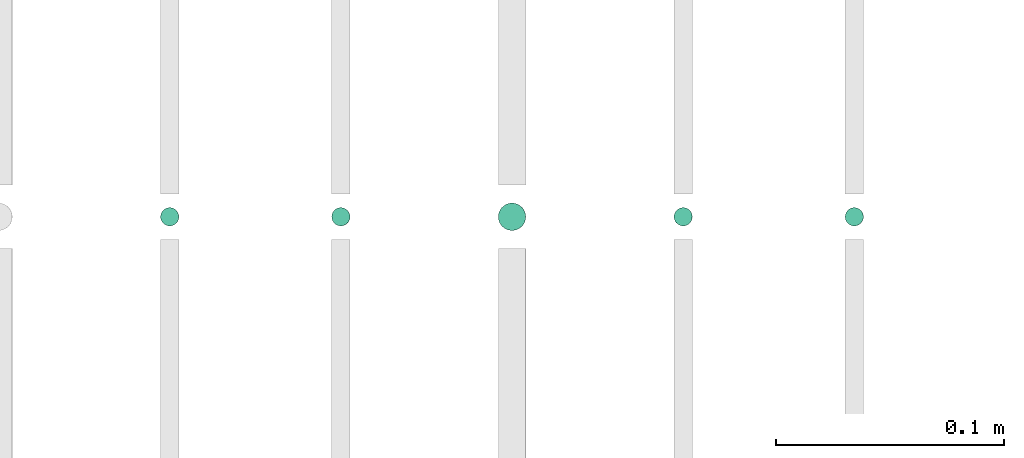
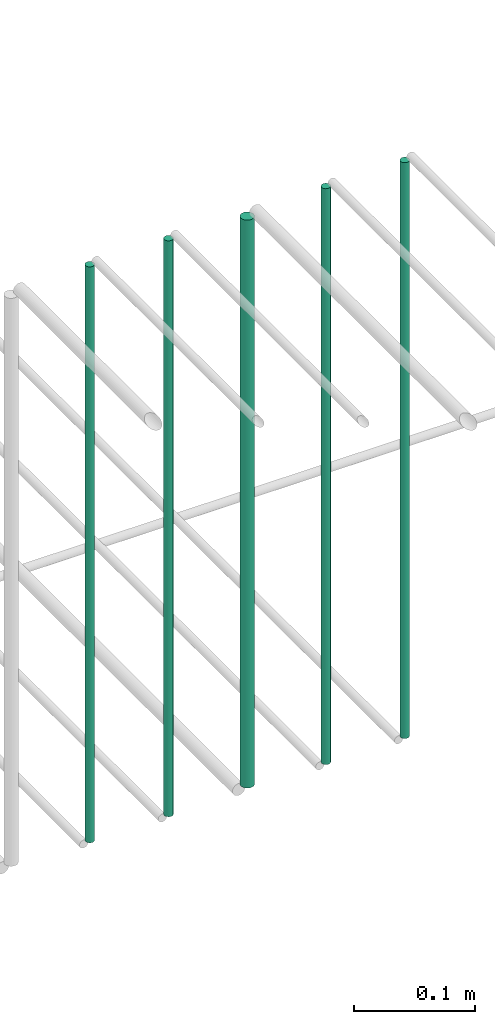
# One storey, part 178 of 331: 5 flow segments.
"""IFC2X3 building model written with IfcOpenShell, lengths in millimetres."""

from ifc_helpers import new_model, entity, si_unit, converted_unit, derived_unit, direction, frame, frame_2d, origin, origin_2d_with_axis, place, context, subcontext, project, spatial, circle, extrude, type_object, element, save


model = new_model("IFC2X3")

# Units and contexts
model_context = context("Model", 3, precision=0.01, world=origin(), true_north=direction((6.12303176911189e-17, 1.0)))
body_context = subcontext(model_context, "Body", "Model", "MODEL_VIEW")
ifc_project = project(units=[si_unit("LENGTHUNIT", "METRE", prefix="MILLI"), si_unit("AREAUNIT", "SQUARE_METRE"), si_unit("VOLUMEUNIT", "CUBIC_METRE"), converted_unit("PLANEANGLEUNIT", "DEGREE", entity("IfcRatioMeasure", 0.0174532925199433), si_unit("PLANEANGLEUNIT", "RADIAN"), dimensions=[0, 0, 0, 0, 0, 0, 0]), si_unit("MASSUNIT", "GRAM", prefix="KILO"), derived_unit("MASSDENSITYUNIT", [(si_unit("MASSUNIT", "GRAM", prefix="KILO"), 1), (si_unit("LENGTHUNIT", "METRE"), -3)]), derived_unit("MOMENTOFINERTIAUNIT", [(si_unit("LENGTHUNIT", "METRE"), 4)]), si_unit("TIMEUNIT", "SECOND"), si_unit("FREQUENCYUNIT", "HERTZ"), si_unit("THERMODYNAMICTEMPERATUREUNIT", "DEGREE_CELSIUS"), derived_unit("THERMALTRANSMITTANCEUNIT", [(si_unit("MASSUNIT", "GRAM", prefix="KILO"), 1), (si_unit("THERMODYNAMICTEMPERATUREUNIT", "KELVIN"), -1), (si_unit("TIMEUNIT", "SECOND"), -3)]), derived_unit("VOLUMETRICFLOWRATEUNIT", [(si_unit("LENGTHUNIT", "METRE"), 3), (si_unit("TIMEUNIT", "SECOND"), -1)]), derived_unit("MASSFLOWRATEUNIT", [(si_unit("MASSUNIT", "GRAM", prefix="KILO"), 1), (si_unit("TIMEUNIT", "SECOND"), -1)]), derived_unit("ROTATIONALFREQUENCYUNIT", [(si_unit("TIMEUNIT", "SECOND"), -1)]), si_unit("ELECTRICCURRENTUNIT", "AMPERE"), si_unit("ELECTRICVOLTAGEUNIT", "VOLT"), si_unit("POWERUNIT", "WATT"), si_unit("FORCEUNIT", "NEWTON", prefix="KILO"), si_unit("ILLUMINANCEUNIT", "LUX"), si_unit("LUMINOUSFLUXUNIT", "LUMEN"), si_unit("LUMINOUSINTENSITYUNIT", "CANDELA"), derived_unit("USERDEFINED", [(si_unit("MASSUNIT", "GRAM", prefix="KILO"), -1), (si_unit("LENGTHUNIT", "METRE"), -2), (si_unit("TIMEUNIT", "SECOND"), 3), (si_unit("LUMINOUSFLUXUNIT", "LUMEN"), 1)]), derived_unit("LINEARVELOCITYUNIT", [(si_unit("LENGTHUNIT", "METRE"), 1), (si_unit("TIMEUNIT", "SECOND"), -1)]), si_unit("PRESSUREUNIT", "PASCAL"), derived_unit("USERDEFINED", [(si_unit("LENGTHUNIT", "METRE"), -2), (si_unit("MASSUNIT", "GRAM", prefix="KILO"), 1), (si_unit("TIMEUNIT", "SECOND"), -2)]), derived_unit("LINEARFORCEUNIT", [(si_unit("MASSUNIT", "GRAM", prefix="KILO"), 1), (si_unit("LENGTHUNIT", "METRE"), 1), (si_unit("TIMEUNIT", "SECOND"), -2), (si_unit("LENGTHUNIT", "METRE"), -1)]), derived_unit("PLANARFORCEUNIT", [(si_unit("MASSUNIT", "GRAM", prefix="KILO"), 1), (si_unit("LENGTHUNIT", "METRE"), 1), (si_unit("TIMEUNIT", "SECOND"), -2), (si_unit("LENGTHUNIT", "METRE"), -2)])], contexts=[model_context])

# Site, building, storey
site_placement = place(None, frame((0.0, -0.00077364408347762, 0.0)))
site = spatial("IfcSite", under=ifc_project, at=site_placement, CompositionType="ELEMENT")
building_placement = place(site_placement, origin())
building = spatial("IfcBuilding", under=site, at=building_placement, CompositionType="ELEMENT")
storey_placement = place(building_placement, origin())
storey = spatial("IfcBuildingStorey", under=building, at=storey_placement, CompositionType="ELEMENT", Elevation=0.0)

# Flow segments
pipe_segment_type = type_object("IfcPipeSegmentType", PredefinedType="NOTDEFINED")
flow_segment_1_placement = place(storey_placement, frame((44864.5706481368, 5638.02529159143, 18460.0)))
element("IfcFlowSegment", 1, at=flow_segment_1_placement, inside=storey, type_object=pipe_segment_type, context=body_context, shape_type="SweptSolid", body=[
    extrude(circle(Radius=4.0, at=origin_2d_with_axis()), frame((5.59527223591499, 5.59527223591607, 0.0), z_axis=(0.0, 0.0, 1.0), x_axis=(-1.0, 0.0, 0.0)), (0.0, 0.0, 1.0), 580.000000000015),
])
flow_segment_2_placement = place(storey_placement, frame((44789.5706481368, 5638.02529159143, 18460.0)))
element("IfcFlowSegment", 2, at=flow_segment_2_placement, inside=storey, type_object=pipe_segment_type, context=body_context, shape_type="SweptSolid", body=[
    extrude(circle(Radius=4.0, at=origin_2d_with_axis()), frame((5.59527223591499, 5.59527223591607, 0.0), z_axis=(0.0, 0.0, 1.0), x_axis=(-1.0, 0.0, 0.0)), (0.0, 0.0, 1.0), 580.000000000007),
])
flow_segment_3_placement = place(storey_placement, frame((44712.5706481368, 5636.02529159143, 18464.0)))
element("IfcFlowSegment", 3, at=flow_segment_3_placement, inside=storey, type_object=pipe_segment_type, context=body_context, shape_type="SweptSolid", body=[
    extrude(circle(Radius=6.0, at=origin_2d_with_axis()), frame((7.59527223591454, 7.59527223591562, 0.0), z_axis=(0.0, 0.0, 1.0), x_axis=(-1.0, 0.0, 0.0)), (0.0, 0.0, 1.0), 572.000000000002),
])
flow_segment_4_placement = place(storey_placement, frame((44639.5706481368, 5638.02529159143, 18460.0)))
element("IfcFlowSegment", 4, at=flow_segment_4_placement, inside=storey, type_object=pipe_segment_type, context=body_context, shape_type="SweptSolid", body=[
    extrude(circle(Radius=4.0, at=origin_2d_with_axis()), frame((5.59527223591499, 5.59527223591607, 0.0), z_axis=(0.0, 0.0, 1.0), x_axis=(-1.0, 0.0, 0.0)), (0.0, 0.0, 1.0), 580.000000000015),
])
flow_segment_5_placement = place(storey_placement, frame((44564.5706481368, 5638.02529159143, 18460.0)))
element("IfcFlowSegment", 5, at=flow_segment_5_placement, inside=storey, type_object=pipe_segment_type, context=body_context, shape_type="SweptSolid", body=[
    extrude(circle(Radius=4.0, at=frame_2d((0.0, -1.08286712929839e-12), x_axis=(1.0, 0.0))), frame((5.59527223591499, 5.59527223591499, 0.0), z_axis=(0.0, 0.0, 1.0), x_axis=(-1.0, 0.0, 0.0)), (0.0, 0.0, 1.0), 580.0),
])

save(model, "model.ifc")
